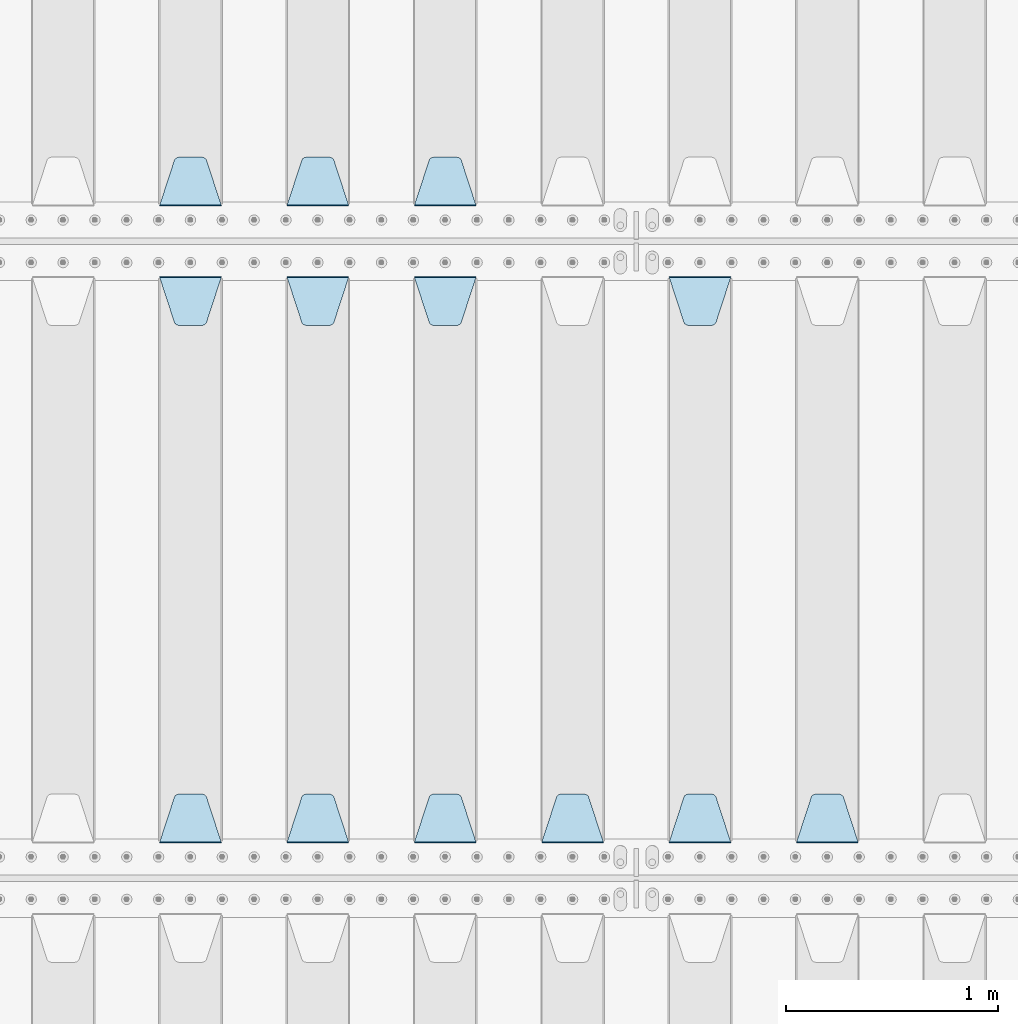
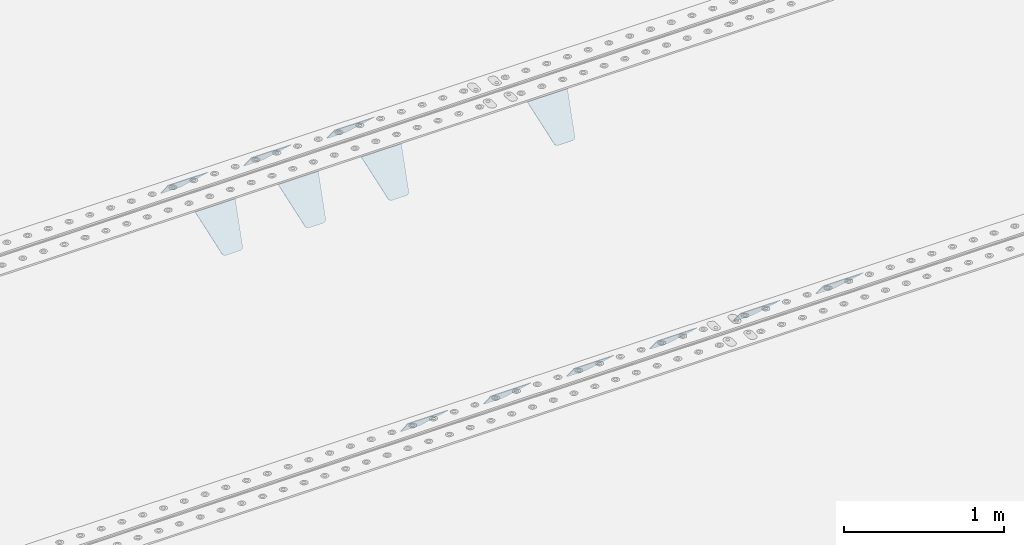
# One storey, part 207 of 257: 13 plates.
"""IFC2X3 building model written with IfcOpenShell, lengths in millimetres."""

from ifc_helpers import new_model, si_unit, frame, origin_with_axes, place, context, subcontext, project, spatial, faceted_brep, material, type_object, element, save


model = new_model("IFC2X3")

# Units and contexts
model_context = context("Model", 3, precision=1e-05, world=origin_with_axes())
body_context = subcontext(model_context, "Body", "Model", "MODEL_VIEW")
ifc_project = project(units=[si_unit("LENGTHUNIT", "METRE", prefix="MILLI"), si_unit("AREAUNIT", "SQUARE_METRE"), si_unit("VOLUMEUNIT", "CUBIC_METRE"), si_unit("MASSUNIT", "GRAM", prefix="KILO"), si_unit("TIMEUNIT", "SECOND"), si_unit("PLANEANGLEUNIT", "RADIAN"), si_unit("SOLIDANGLEUNIT", "STERADIAN"), si_unit("THERMODYNAMICTEMPERATUREUNIT", "DEGREE_CELSIUS"), si_unit("LUMINOUSINTENSITYUNIT", "LUMEN")], contexts=[model_context])

# Site, building, storey
site_placement = place(None, origin_with_axes())
site = spatial("IfcSite", under=ifc_project, at=site_placement, CompositionType="ELEMENT")
building_placement = place(site_placement, origin_with_axes())
building = spatial("IfcBuilding", under=site, at=building_placement, Name="Standard", CompositionType="ELEMENT")
storey_placement = place(building_placement, origin_with_axes())
storey = spatial("IfcBuildingStorey", under=building, at=storey_placement, Name="Undefined", CompositionType="ELEMENT", Elevation=0.0)

# Plates
ifc_material = material(Name="STEEL/S355N")
plate_type = type_object("IfcPlateType", PredefinedType="NOTDEFINED")
plate_1_placement = place(storey_placement, frame((47195.0, 6168.23223304703, -1.76776695296758), z_axis=(0.0, 0.707106781186547, -0.707106781186548), x_axis=(-1.0, 0.0, 0.0)))
element("IfcPlate", 1, at=plate_1_placement, inside=storey, type_object=plate_type, material=ifc_material, context=body_context, shape_type="Brep", body=[
    faceted_brep([(0.0, -2.5, 0.0), (69.345504679477, -2.50000000000091, 300.17173142483), (69.345504679477, 2.5, 300.171731424831), (0.0, 2.5, 0.0), (70.927406119954, -2.50000000000091, 304.8974424154), (70.927406119954, 2.5, 304.8974424154), (73.3818627772271, -2.50000000000091, 309.234538108527), (73.3818627772271, 2.49999999999909, 309.234538108527), (76.6187032999587, -2.5, 313.023683126103), (76.6187032999587, 2.5, 313.023683126103), (80.5190132705029, -2.5, 316.125672595372), (80.5190132705029, 2.5, 316.125672595371), (84.9395038596849, -2.5, 318.426546230476), (84.9395038596849, 2.5, 318.426546230477), (89.7177759439219, -2.5, 319.841774983275), (89.7177759439219, 2.5, 319.841774983275), (94.6782862926484, -2.5, 320.319366455079), (94.6782862926484, 2.5, 320.319366455079), (195.321713707352, -2.5, 320.319366455079), (195.321713707352, 2.5, 320.319366455079), (200.282224056078, -2.5, 319.841774983275), (200.282224056078, 2.49999999999909, 319.841774983275), (205.060496140315, -2.5, 318.426546230476), (205.060496140315, 2.49999999999909, 318.426546230475), (209.480986729497, -2.5, 316.125672595371), (209.480986729497, 2.5, 316.125672595371), (213.381296700041, -2.50000000000091, 313.023683126102), (213.381296700041, 2.5, 313.023683126103), (216.618137222766, -2.50000000000091, 309.234538108527), (216.618137222766, 2.5, 309.234538108527), (219.072593880039, -2.5, 304.897442415399), (219.072593880039, 2.5, 304.897442415399), (220.654495320523, -2.50000000000091, 300.17173142483), (220.654495320523, 2.5, 300.171731424831), (290.0, -2.50000000000091, 0.0), (290.0, 2.5, 9.09494701772928e-13)], [[[0, 1, 2, 3]], [[1, 4, 5, 2]], [[4, 6, 7, 5]], [[6, 8, 9, 7]], [[8, 10, 11, 9]], [[10, 12, 13, 11]], [[12, 14, 15, 13]], [[14, 16, 17, 15]], [[16, 18, 19, 17]], [[18, 20, 21, 19]], [[20, 22, 23, 21]], [[22, 24, 25, 23]], [[24, 26, 27, 25]], [[26, 28, 29, 27]], [[28, 30, 31, 29]], [[30, 32, 33, 31]], [[32, 34, 35, 33]], [[34, 0, 3, 35]], [[5, 7, 9, 11, 13, 15, 17, 19, 21, 23, 25, 27, 29, 31, 33, 35, 3, 2]], [[34, 32, 30, 28, 26, 24, 22, 20, 18, 16, 14, 12, 10, 8, 6, 4, 1, 0]]]),
])
plate_2_placement = place(storey_placement, frame((46595.0, 6168.23223304703, -1.76776695296758), z_axis=(0.0, 0.707106781186547, -0.707106781186548), x_axis=(-1.0, 0.0, 0.0)))
element("IfcPlate", 2, at=plate_2_placement, inside=storey, type_object=plate_type, material=ifc_material, context=body_context, shape_type="Brep", body=[
    faceted_brep([(0.0, -2.5, 0.0), (69.345504679477, -2.50000000000091, 300.17173142483), (69.345504679477, 2.5, 300.171731424831), (0.0, 2.5, 0.0), (70.927406119954, -2.50000000000091, 304.8974424154), (70.927406119954, 2.5, 304.8974424154), (73.3818627772271, -2.50000000000091, 309.234538108527), (73.3818627772271, 2.49999999999909, 309.234538108527), (76.6187032999587, -2.5, 313.023683126103), (76.6187032999587, 2.5, 313.023683126103), (80.5190132705029, -2.5, 316.125672595372), (80.5190132705029, 2.5, 316.125672595371), (84.9395038596849, -2.5, 318.426546230476), (84.9395038596849, 2.5, 318.426546230477), (89.7177759439219, -2.5, 319.841774983275), (89.7177759439219, 2.5, 319.841774983275), (94.6782862926484, -2.5, 320.319366455079), (94.6782862926484, 2.5, 320.319366455079), (195.321713707352, -2.5, 320.319366455079), (195.321713707352, 2.5, 320.319366455079), (200.282224056078, -2.5, 319.841774983275), (200.282224056078, 2.49999999999909, 319.841774983275), (205.060496140315, -2.5, 318.426546230476), (205.060496140315, 2.49999999999909, 318.426546230475), (209.480986729497, -2.5, 316.125672595371), (209.480986729497, 2.5, 316.125672595371), (213.381296700041, -2.50000000000091, 313.023683126102), (213.381296700041, 2.5, 313.023683126103), (216.618137222766, -2.50000000000091, 309.234538108527), (216.618137222766, 2.5, 309.234538108527), (219.072593880039, -2.5, 304.897442415399), (219.072593880039, 2.5, 304.897442415399), (220.654495320523, -2.50000000000091, 300.17173142483), (220.654495320523, 2.5, 300.171731424831), (290.0, -2.50000000000091, 0.0), (290.0, 2.5, 9.09494701772928e-13)], [[[0, 1, 2, 3]], [[1, 4, 5, 2]], [[4, 6, 7, 5]], [[6, 8, 9, 7]], [[8, 10, 11, 9]], [[10, 12, 13, 11]], [[12, 14, 15, 13]], [[14, 16, 17, 15]], [[16, 18, 19, 17]], [[18, 20, 21, 19]], [[20, 22, 23, 21]], [[22, 24, 25, 23]], [[24, 26, 27, 25]], [[26, 28, 29, 27]], [[28, 30, 31, 29]], [[30, 32, 33, 31]], [[32, 34, 35, 33]], [[34, 0, 3, 35]], [[5, 7, 9, 11, 13, 15, 17, 19, 21, 23, 25, 27, 29, 31, 33, 35, 3, 2]], [[34, 32, 30, 28, 26, 24, 22, 20, 18, 16, 14, 12, 10, 8, 6, 4, 1, 0]]]),
])
plate_3_placement = place(storey_placement, frame((45995.0, 6168.23223304703, -1.76776695296758), z_axis=(0.0, 0.707106781186547, -0.707106781186548), x_axis=(-1.0, 0.0, 0.0)))
element("IfcPlate", 3, at=plate_3_placement, inside=storey, type_object=plate_type, material=ifc_material, context=body_context, shape_type="Brep", body=[
    faceted_brep([(0.0, -2.5, 0.0), (69.345504679477, -2.50000000000091, 300.17173142483), (69.345504679477, 2.5, 300.171731424831), (0.0, 2.5, 0.0), (70.927406119954, -2.50000000000091, 304.8974424154), (70.927406119954, 2.5, 304.8974424154), (73.3818627772271, -2.50000000000091, 309.234538108527), (73.3818627772271, 2.49999999999909, 309.234538108527), (76.6187032999587, -2.5, 313.023683126103), (76.6187032999587, 2.5, 313.023683126103), (80.5190132705029, -2.5, 316.125672595372), (80.5190132705029, 2.5, 316.125672595371), (84.9395038596849, -2.5, 318.426546230476), (84.9395038596849, 2.5, 318.426546230477), (89.7177759439219, -2.5, 319.841774983275), (89.7177759439219, 2.5, 319.841774983275), (94.6782862926484, -2.5, 320.319366455079), (94.6782862926484, 2.5, 320.319366455079), (195.321713707352, -2.5, 320.319366455079), (195.321713707352, 2.5, 320.319366455079), (200.282224056078, -2.5, 319.841774983275), (200.282224056078, 2.49999999999909, 319.841774983275), (205.060496140315, -2.5, 318.426546230476), (205.060496140315, 2.49999999999909, 318.426546230475), (209.480986729497, -2.5, 316.125672595371), (209.480986729497, 2.5, 316.125672595371), (213.381296700041, -2.50000000000091, 313.023683126102), (213.381296700041, 2.5, 313.023683126103), (216.618137222766, -2.50000000000091, 309.234538108527), (216.618137222766, 2.5, 309.234538108527), (219.072593880039, -2.5, 304.897442415399), (219.072593880039, 2.5, 304.897442415399), (220.654495320523, -2.50000000000091, 300.17173142483), (220.654495320523, 2.5, 300.171731424831), (290.0, -2.50000000000091, 0.0), (290.0, 2.5, 9.09494701772928e-13)], [[[0, 1, 2, 3]], [[1, 4, 5, 2]], [[4, 6, 7, 5]], [[6, 8, 9, 7]], [[8, 10, 11, 9]], [[10, 12, 13, 11]], [[12, 14, 15, 13]], [[14, 16, 17, 15]], [[16, 18, 19, 17]], [[18, 20, 21, 19]], [[20, 22, 23, 21]], [[22, 24, 25, 23]], [[24, 26, 27, 25]], [[26, 28, 29, 27]], [[28, 30, 31, 29]], [[30, 32, 33, 31]], [[32, 34, 35, 33]], [[34, 0, 3, 35]], [[5, 7, 9, 11, 13, 15, 17, 19, 21, 23, 25, 27, 29, 31, 33, 35, 3, 2]], [[34, 32, 30, 28, 26, 24, 22, 20, 18, 16, 14, 12, 10, 8, 6, 4, 1, 0]]]),
])
plate_4_placement = place(storey_placement, frame((48995.0, 3168.23223304703, -1.76776695296758), z_axis=(0.0, 0.707106781186547, -0.707106781186548), x_axis=(-1.0, 0.0, 0.0)))
element("IfcPlate", 4, at=plate_4_placement, inside=storey, type_object=plate_type, material=ifc_material, context=body_context, shape_type="Brep", body=[
    faceted_brep([(0.0, -2.5, 0.0), (69.345504679477, -2.50000000000091, 300.17173142483), (69.345504679477, 2.5, 300.171731424831), (0.0, 2.5, 0.0), (70.927406119954, -2.50000000000091, 304.8974424154), (70.927406119954, 2.5, 304.8974424154), (73.3818627772271, -2.50000000000091, 309.234538108527), (73.3818627772271, 2.49999999999909, 309.234538108527), (76.6187032999587, -2.5, 313.023683126103), (76.6187032999587, 2.5, 313.023683126103), (80.5190132705029, -2.5, 316.125672595372), (80.5190132705029, 2.5, 316.125672595371), (84.9395038596849, -2.5, 318.426546230476), (84.9395038596849, 2.5, 318.426546230477), (89.7177759439219, -2.5, 319.841774983275), (89.7177759439219, 2.5, 319.841774983275), (94.6782862926484, -2.5, 320.319366455079), (94.6782862926484, 2.5, 320.319366455079), (195.321713707352, -2.5, 320.319366455079), (195.321713707352, 2.5, 320.319366455079), (200.282224056078, -2.5, 319.841774983275), (200.282224056078, 2.49999999999909, 319.841774983275), (205.060496140315, -2.5, 318.426546230476), (205.060496140315, 2.49999999999909, 318.426546230475), (209.480986729497, -2.5, 316.125672595371), (209.480986729497, 2.5, 316.125672595371), (213.381296700041, -2.50000000000091, 313.023683126102), (213.381296700041, 2.5, 313.023683126103), (216.618137222766, -2.50000000000091, 309.234538108527), (216.618137222766, 2.5, 309.234538108527), (219.072593880039, -2.5, 304.897442415399), (219.072593880039, 2.5, 304.897442415399), (220.654495320523, -2.50000000000091, 300.17173142483), (220.654495320523, 2.5, 300.171731424831), (290.0, -2.50000000000091, 0.0), (290.0, 2.5, 9.09494701772928e-13)], [[[0, 1, 2, 3]], [[1, 4, 5, 2]], [[4, 6, 7, 5]], [[6, 8, 9, 7]], [[8, 10, 11, 9]], [[10, 12, 13, 11]], [[12, 14, 15, 13]], [[14, 16, 17, 15]], [[16, 18, 19, 17]], [[18, 20, 21, 19]], [[20, 22, 23, 21]], [[22, 24, 25, 23]], [[24, 26, 27, 25]], [[26, 28, 29, 27]], [[28, 30, 31, 29]], [[30, 32, 33, 31]], [[32, 34, 35, 33]], [[34, 0, 3, 35]], [[5, 7, 9, 11, 13, 15, 17, 19, 21, 23, 25, 27, 29, 31, 33, 35, 3, 2]], [[34, 32, 30, 28, 26, 24, 22, 20, 18, 16, 14, 12, 10, 8, 6, 4, 1, 0]]]),
])
plate_5_placement = place(storey_placement, frame((48105.0, 5831.76776695594, -1.767766952965), z_axis=(0.0, -0.707106781186548, -0.707106781186547), x_axis=(1.0, 0.0, 0.0)))
element("IfcPlate", 5, at=plate_5_placement, inside=storey, type_object=plate_type, material=ifc_material, context=body_context, shape_type="Brep", body=[
    faceted_brep([(0.0, -2.5, 0.0), (69.345504679477, -2.50000000000091, 300.17173142483), (69.345504679477, 2.5, 300.171731424831), (0.0, 2.5, 0.0), (70.927406119954, -2.50000000000091, 304.8974424154), (70.927406119954, 2.5, 304.8974424154), (73.3818627772271, -2.50000000000091, 309.234538108527), (73.3818627772271, 2.49999999999909, 309.234538108527), (76.6187032999587, -2.5, 313.023683126103), (76.6187032999587, 2.5, 313.023683126103), (80.5190132705029, -2.5, 316.125672595372), (80.5190132705029, 2.5, 316.125672595371), (84.9395038596849, -2.5, 318.426546230476), (84.9395038596849, 2.5, 318.426546230477), (89.7177759439219, -2.5, 319.841774983275), (89.7177759439219, 2.5, 319.841774983275), (94.6782862926484, -2.5, 320.319366455079), (94.6782862926484, 2.5, 320.319366455079), (195.321713707352, -2.5, 320.319366455079), (195.321713707352, 2.5, 320.319366455079), (200.282224056078, -2.5, 319.841774983275), (200.282224056078, 2.49999999999909, 319.841774983275), (205.060496140315, -2.5, 318.426546230476), (205.060496140315, 2.49999999999909, 318.426546230475), (209.480986729497, -2.5, 316.125672595371), (209.480986729497, 2.5, 316.125672595371), (213.381296700041, -2.50000000000091, 313.023683126102), (213.381296700041, 2.5, 313.023683126103), (216.618137222766, -2.50000000000091, 309.234538108527), (216.618137222766, 2.5, 309.234538108527), (219.072593880039, -2.5, 304.897442415399), (219.072593880039, 2.5, 304.897442415399), (220.654495320523, -2.50000000000091, 300.17173142483), (220.654495320523, 2.5, 300.171731424831), (290.0, -2.50000000000091, 0.0), (290.0, 2.5, 9.09494701772928e-13)], [[[0, 1, 2, 3]], [[1, 4, 5, 2]], [[4, 6, 7, 5]], [[6, 8, 9, 7]], [[8, 10, 11, 9]], [[10, 12, 13, 11]], [[12, 14, 15, 13]], [[14, 16, 17, 15]], [[16, 18, 19, 17]], [[18, 20, 21, 19]], [[20, 22, 23, 21]], [[22, 24, 25, 23]], [[24, 26, 27, 25]], [[26, 28, 29, 27]], [[28, 30, 31, 29]], [[30, 32, 33, 31]], [[32, 34, 35, 33]], [[34, 0, 3, 35]], [[5, 7, 9, 11, 13, 15, 17, 19, 21, 23, 25, 27, 29, 31, 33, 35, 3, 2]], [[34, 32, 30, 28, 26, 24, 22, 20, 18, 16, 14, 12, 10, 8, 6, 4, 1, 0]]]),
])
plate_6_placement = place(storey_placement, frame((48395.0, 3168.23223304703, -1.76776695296758), z_axis=(0.0, 0.707106781186547, -0.707106781186548), x_axis=(-1.0, 0.0, 0.0)))
element("IfcPlate", 6, at=plate_6_placement, inside=storey, type_object=plate_type, material=ifc_material, context=body_context, shape_type="Brep", body=[
    faceted_brep([(0.0, -2.5, 0.0), (69.345504679477, -2.50000000000091, 300.17173142483), (69.345504679477, 2.5, 300.171731424831), (0.0, 2.5, 0.0), (70.927406119954, -2.50000000000091, 304.8974424154), (70.927406119954, 2.5, 304.8974424154), (73.3818627772271, -2.50000000000091, 309.234538108527), (73.3818627772271, 2.49999999999909, 309.234538108527), (76.6187032999587, -2.5, 313.023683126103), (76.6187032999587, 2.5, 313.023683126103), (80.5190132705029, -2.5, 316.125672595372), (80.5190132705029, 2.5, 316.125672595371), (84.9395038596849, -2.5, 318.426546230476), (84.9395038596849, 2.5, 318.426546230477), (89.7177759439219, -2.5, 319.841774983275), (89.7177759439219, 2.5, 319.841774983275), (94.6782862926484, -2.5, 320.319366455079), (94.6782862926484, 2.5, 320.319366455079), (195.321713707352, -2.5, 320.319366455079), (195.321713707352, 2.5, 320.319366455079), (200.282224056078, -2.5, 319.841774983275), (200.282224056078, 2.49999999999909, 319.841774983275), (205.060496140315, -2.5, 318.426546230476), (205.060496140315, 2.49999999999909, 318.426546230475), (209.480986729497, -2.5, 316.125672595371), (209.480986729497, 2.5, 316.125672595371), (213.381296700041, -2.50000000000091, 313.023683126102), (213.381296700041, 2.5, 313.023683126103), (216.618137222766, -2.50000000000091, 309.234538108527), (216.618137222766, 2.5, 309.234538108527), (219.072593880039, -2.5, 304.897442415399), (219.072593880039, 2.5, 304.897442415399), (220.654495320523, -2.50000000000091, 300.17173142483), (220.654495320523, 2.5, 300.171731424831), (290.0, -2.50000000000091, 0.0), (290.0, 2.5, 9.09494701772928e-13)], [[[0, 1, 2, 3]], [[1, 4, 5, 2]], [[4, 6, 7, 5]], [[6, 8, 9, 7]], [[8, 10, 11, 9]], [[10, 12, 13, 11]], [[12, 14, 15, 13]], [[14, 16, 17, 15]], [[16, 18, 19, 17]], [[18, 20, 21, 19]], [[20, 22, 23, 21]], [[22, 24, 25, 23]], [[24, 26, 27, 25]], [[26, 28, 29, 27]], [[28, 30, 31, 29]], [[30, 32, 33, 31]], [[32, 34, 35, 33]], [[34, 0, 3, 35]], [[5, 7, 9, 11, 13, 15, 17, 19, 21, 23, 25, 27, 29, 31, 33, 35, 3, 2]], [[34, 32, 30, 28, 26, 24, 22, 20, 18, 16, 14, 12, 10, 8, 6, 4, 1, 0]]]),
])
plate_7_placement = place(storey_placement, frame((47795.0, 3168.23223304703, -1.76776695296758), z_axis=(0.0, 0.707106781186547, -0.707106781186548), x_axis=(-1.0, 0.0, 0.0)))
element("IfcPlate", 7, at=plate_7_placement, inside=storey, type_object=plate_type, material=ifc_material, context=body_context, shape_type="Brep", body=[
    faceted_brep([(0.0, -2.5, 0.0), (69.345504679477, -2.50000000000091, 300.17173142483), (69.345504679477, 2.5, 300.171731424831), (0.0, 2.5, 0.0), (70.927406119954, -2.50000000000091, 304.8974424154), (70.927406119954, 2.5, 304.8974424154), (73.3818627772271, -2.50000000000091, 309.234538108527), (73.3818627772271, 2.49999999999909, 309.234538108527), (76.6187032999587, -2.5, 313.023683126103), (76.6187032999587, 2.5, 313.023683126103), (80.5190132705029, -2.5, 316.125672595372), (80.5190132705029, 2.5, 316.125672595371), (84.9395038596849, -2.5, 318.426546230476), (84.9395038596849, 2.5, 318.426546230477), (89.7177759439219, -2.5, 319.841774983275), (89.7177759439219, 2.5, 319.841774983275), (94.6782862926484, -2.5, 320.319366455079), (94.6782862926484, 2.5, 320.319366455079), (195.321713707352, -2.5, 320.319366455079), (195.321713707352, 2.5, 320.319366455079), (200.282224056078, -2.5, 319.841774983275), (200.282224056078, 2.49999999999909, 319.841774983275), (205.060496140315, -2.5, 318.426546230476), (205.060496140315, 2.49999999999909, 318.426546230475), (209.480986729497, -2.5, 316.125672595371), (209.480986729497, 2.5, 316.125672595371), (213.381296700041, -2.50000000000091, 313.023683126102), (213.381296700041, 2.5, 313.023683126103), (216.618137222766, -2.50000000000091, 309.234538108527), (216.618137222766, 2.5, 309.234538108527), (219.072593880039, -2.5, 304.897442415399), (219.072593880039, 2.5, 304.897442415399), (220.654495320523, -2.50000000000091, 300.17173142483), (220.654495320523, 2.5, 300.171731424831), (290.0, -2.50000000000091, 0.0), (290.0, 2.5, 9.09494701772928e-13)], [[[0, 1, 2, 3]], [[1, 4, 5, 2]], [[4, 6, 7, 5]], [[6, 8, 9, 7]], [[8, 10, 11, 9]], [[10, 12, 13, 11]], [[12, 14, 15, 13]], [[14, 16, 17, 15]], [[16, 18, 19, 17]], [[18, 20, 21, 19]], [[20, 22, 23, 21]], [[22, 24, 25, 23]], [[24, 26, 27, 25]], [[26, 28, 29, 27]], [[28, 30, 31, 29]], [[30, 32, 33, 31]], [[32, 34, 35, 33]], [[34, 0, 3, 35]], [[5, 7, 9, 11, 13, 15, 17, 19, 21, 23, 25, 27, 29, 31, 33, 35, 3, 2]], [[34, 32, 30, 28, 26, 24, 22, 20, 18, 16, 14, 12, 10, 8, 6, 4, 1, 0]]]),
])
plate_8_placement = place(storey_placement, frame((46905.0, 5831.76776695594, -1.767766952965), z_axis=(0.0, -0.707106781186548, -0.707106781186547), x_axis=(1.0, 0.0, 0.0)))
element("IfcPlate", 8, at=plate_8_placement, inside=storey, type_object=plate_type, material=ifc_material, context=body_context, shape_type="Brep", body=[
    faceted_brep([(0.0, -2.5, 0.0), (69.345504679477, -2.50000000000091, 300.17173142483), (69.345504679477, 2.5, 300.171731424831), (0.0, 2.5, 0.0), (70.927406119954, -2.50000000000091, 304.8974424154), (70.927406119954, 2.5, 304.8974424154), (73.3818627772271, -2.50000000000091, 309.234538108527), (73.3818627772271, 2.49999999999909, 309.234538108527), (76.6187032999587, -2.5, 313.023683126103), (76.6187032999587, 2.5, 313.023683126103), (80.5190132705029, -2.5, 316.125672595372), (80.5190132705029, 2.5, 316.125672595371), (84.9395038596849, -2.5, 318.426546230476), (84.9395038596849, 2.5, 318.426546230477), (89.7177759439219, -2.5, 319.841774983275), (89.7177759439219, 2.5, 319.841774983275), (94.6782862926484, -2.5, 320.319366455079), (94.6782862926484, 2.5, 320.319366455079), (195.321713707352, -2.5, 320.319366455079), (195.321713707352, 2.5, 320.319366455079), (200.282224056078, -2.5, 319.841774983275), (200.282224056078, 2.49999999999909, 319.841774983275), (205.060496140315, -2.5, 318.426546230476), (205.060496140315, 2.49999999999909, 318.426546230475), (209.480986729497, -2.5, 316.125672595371), (209.480986729497, 2.5, 316.125672595371), (213.381296700041, -2.50000000000091, 313.023683126102), (213.381296700041, 2.5, 313.023683126103), (216.618137222766, -2.50000000000091, 309.234538108527), (216.618137222766, 2.5, 309.234538108527), (219.072593880039, -2.5, 304.897442415399), (219.072593880039, 2.5, 304.897442415399), (220.654495320523, -2.50000000000091, 300.17173142483), (220.654495320523, 2.5, 300.171731424831), (290.0, -2.50000000000091, 0.0), (290.0, 2.5, 9.09494701772928e-13)], [[[0, 1, 2, 3]], [[1, 4, 5, 2]], [[4, 6, 7, 5]], [[6, 8, 9, 7]], [[8, 10, 11, 9]], [[10, 12, 13, 11]], [[12, 14, 15, 13]], [[14, 16, 17, 15]], [[16, 18, 19, 17]], [[18, 20, 21, 19]], [[20, 22, 23, 21]], [[22, 24, 25, 23]], [[24, 26, 27, 25]], [[26, 28, 29, 27]], [[28, 30, 31, 29]], [[30, 32, 33, 31]], [[32, 34, 35, 33]], [[34, 0, 3, 35]], [[5, 7, 9, 11, 13, 15, 17, 19, 21, 23, 25, 27, 29, 31, 33, 35, 3, 2]], [[34, 32, 30, 28, 26, 24, 22, 20, 18, 16, 14, 12, 10, 8, 6, 4, 1, 0]]]),
])
plate_9_placement = place(storey_placement, frame((47195.0, 3168.23223304703, -1.76776695296758), z_axis=(0.0, 0.707106781186547, -0.707106781186548), x_axis=(-1.0, 0.0, 0.0)))
element("IfcPlate", 9, at=plate_9_placement, inside=storey, type_object=plate_type, material=ifc_material, context=body_context, shape_type="Brep", body=[
    faceted_brep([(0.0, -2.5, 0.0), (69.345504679477, -2.50000000000091, 300.17173142483), (69.345504679477, 2.5, 300.171731424831), (0.0, 2.5, 0.0), (70.927406119954, -2.50000000000091, 304.8974424154), (70.927406119954, 2.5, 304.8974424154), (73.3818627772271, -2.50000000000091, 309.234538108527), (73.3818627772271, 2.49999999999909, 309.234538108527), (76.6187032999587, -2.5, 313.023683126103), (76.6187032999587, 2.5, 313.023683126103), (80.5190132705029, -2.5, 316.125672595372), (80.5190132705029, 2.5, 316.125672595371), (84.9395038596849, -2.5, 318.426546230476), (84.9395038596849, 2.5, 318.426546230477), (89.7177759439219, -2.5, 319.841774983275), (89.7177759439219, 2.5, 319.841774983275), (94.6782862926484, -2.5, 320.319366455079), (94.6782862926484, 2.5, 320.319366455079), (195.321713707352, -2.5, 320.319366455079), (195.321713707352, 2.5, 320.319366455079), (200.282224056078, -2.5, 319.841774983275), (200.282224056078, 2.49999999999909, 319.841774983275), (205.060496140315, -2.5, 318.426546230476), (205.060496140315, 2.49999999999909, 318.426546230475), (209.480986729497, -2.5, 316.125672595371), (209.480986729497, 2.5, 316.125672595371), (213.381296700041, -2.50000000000091, 313.023683126102), (213.381296700041, 2.5, 313.023683126103), (216.618137222766, -2.50000000000091, 309.234538108527), (216.618137222766, 2.5, 309.234538108527), (219.072593880039, -2.5, 304.897442415399), (219.072593880039, 2.5, 304.897442415399), (220.654495320523, -2.50000000000091, 300.17173142483), (220.654495320523, 2.5, 300.171731424831), (290.0, -2.50000000000091, 0.0), (290.0, 2.5, 9.09494701772928e-13)], [[[0, 1, 2, 3]], [[1, 4, 5, 2]], [[4, 6, 7, 5]], [[6, 8, 9, 7]], [[8, 10, 11, 9]], [[10, 12, 13, 11]], [[12, 14, 15, 13]], [[14, 16, 17, 15]], [[16, 18, 19, 17]], [[18, 20, 21, 19]], [[20, 22, 23, 21]], [[22, 24, 25, 23]], [[24, 26, 27, 25]], [[26, 28, 29, 27]], [[28, 30, 31, 29]], [[30, 32, 33, 31]], [[32, 34, 35, 33]], [[34, 0, 3, 35]], [[5, 7, 9, 11, 13, 15, 17, 19, 21, 23, 25, 27, 29, 31, 33, 35, 3, 2]], [[34, 32, 30, 28, 26, 24, 22, 20, 18, 16, 14, 12, 10, 8, 6, 4, 1, 0]]]),
])
plate_10_placement = place(storey_placement, frame((46305.0, 5831.76776695594, -1.767766952965), z_axis=(0.0, -0.707106781186548, -0.707106781186547), x_axis=(1.0, 0.0, 0.0)))
element("IfcPlate", 10, at=plate_10_placement, inside=storey, type_object=plate_type, material=ifc_material, context=body_context, shape_type="Brep", body=[
    faceted_brep([(0.0, -2.5, 0.0), (69.345504679477, -2.50000000000091, 300.17173142483), (69.345504679477, 2.5, 300.171731424831), (0.0, 2.5, 0.0), (70.927406119954, -2.50000000000091, 304.8974424154), (70.927406119954, 2.5, 304.8974424154), (73.3818627772271, -2.50000000000091, 309.234538108527), (73.3818627772271, 2.49999999999909, 309.234538108527), (76.6187032999587, -2.5, 313.023683126103), (76.6187032999587, 2.5, 313.023683126103), (80.5190132705029, -2.5, 316.125672595372), (80.5190132705029, 2.5, 316.125672595371), (84.9395038596849, -2.5, 318.426546230476), (84.9395038596849, 2.5, 318.426546230477), (89.7177759439219, -2.5, 319.841774983275), (89.7177759439219, 2.5, 319.841774983275), (94.6782862926484, -2.5, 320.319366455079), (94.6782862926484, 2.5, 320.319366455079), (195.321713707352, -2.5, 320.319366455079), (195.321713707352, 2.5, 320.319366455079), (200.282224056078, -2.5, 319.841774983275), (200.282224056078, 2.49999999999909, 319.841774983275), (205.060496140315, -2.5, 318.426546230476), (205.060496140315, 2.49999999999909, 318.426546230475), (209.480986729497, -2.5, 316.125672595371), (209.480986729497, 2.5, 316.125672595371), (213.381296700041, -2.50000000000091, 313.023683126102), (213.381296700041, 2.5, 313.023683126103), (216.618137222766, -2.50000000000091, 309.234538108527), (216.618137222766, 2.5, 309.234538108527), (219.072593880039, -2.5, 304.897442415399), (219.072593880039, 2.5, 304.897442415399), (220.654495320523, -2.50000000000091, 300.17173142483), (220.654495320523, 2.5, 300.171731424831), (290.0, -2.50000000000091, 0.0), (290.0, 2.5, 9.09494701772928e-13)], [[[0, 1, 2, 3]], [[1, 4, 5, 2]], [[4, 6, 7, 5]], [[6, 8, 9, 7]], [[8, 10, 11, 9]], [[10, 12, 13, 11]], [[12, 14, 15, 13]], [[14, 16, 17, 15]], [[16, 18, 19, 17]], [[18, 20, 21, 19]], [[20, 22, 23, 21]], [[22, 24, 25, 23]], [[24, 26, 27, 25]], [[26, 28, 29, 27]], [[28, 30, 31, 29]], [[30, 32, 33, 31]], [[32, 34, 35, 33]], [[34, 0, 3, 35]], [[5, 7, 9, 11, 13, 15, 17, 19, 21, 23, 25, 27, 29, 31, 33, 35, 3, 2]], [[34, 32, 30, 28, 26, 24, 22, 20, 18, 16, 14, 12, 10, 8, 6, 4, 1, 0]]]),
])
plate_11_placement = place(storey_placement, frame((46595.0, 3168.23223304703, -1.76776695296758), z_axis=(0.0, 0.707106781186547, -0.707106781186548), x_axis=(-1.0, 0.0, 0.0)))
element("IfcPlate", 11, at=plate_11_placement, inside=storey, type_object=plate_type, material=ifc_material, context=body_context, shape_type="Brep", body=[
    faceted_brep([(0.0, -2.5, 0.0), (69.345504679477, -2.50000000000091, 300.17173142483), (69.345504679477, 2.5, 300.171731424831), (0.0, 2.5, 0.0), (70.927406119954, -2.50000000000091, 304.8974424154), (70.927406119954, 2.5, 304.8974424154), (73.3818627772271, -2.50000000000091, 309.234538108527), (73.3818627772271, 2.49999999999909, 309.234538108527), (76.6187032999587, -2.5, 313.023683126103), (76.6187032999587, 2.5, 313.023683126103), (80.5190132705029, -2.5, 316.125672595372), (80.5190132705029, 2.5, 316.125672595371), (84.9395038596849, -2.5, 318.426546230476), (84.9395038596849, 2.5, 318.426546230477), (89.7177759439219, -2.5, 319.841774983275), (89.7177759439219, 2.5, 319.841774983275), (94.6782862926484, -2.5, 320.319366455079), (94.6782862926484, 2.5, 320.319366455079), (195.321713707352, -2.5, 320.319366455079), (195.321713707352, 2.5, 320.319366455079), (200.282224056078, -2.5, 319.841774983275), (200.282224056078, 2.49999999999909, 319.841774983275), (205.060496140315, -2.5, 318.426546230476), (205.060496140315, 2.49999999999909, 318.426546230475), (209.480986729497, -2.5, 316.125672595371), (209.480986729497, 2.5, 316.125672595371), (213.381296700041, -2.50000000000091, 313.023683126102), (213.381296700041, 2.5, 313.023683126103), (216.618137222766, -2.50000000000091, 309.234538108527), (216.618137222766, 2.5, 309.234538108527), (219.072593880039, -2.5, 304.897442415399), (219.072593880039, 2.5, 304.897442415399), (220.654495320523, -2.50000000000091, 300.17173142483), (220.654495320523, 2.5, 300.171731424831), (290.0, -2.50000000000091, 0.0), (290.0, 2.5, 9.09494701772928e-13)], [[[0, 1, 2, 3]], [[1, 4, 5, 2]], [[4, 6, 7, 5]], [[6, 8, 9, 7]], [[8, 10, 11, 9]], [[10, 12, 13, 11]], [[12, 14, 15, 13]], [[14, 16, 17, 15]], [[16, 18, 19, 17]], [[18, 20, 21, 19]], [[20, 22, 23, 21]], [[22, 24, 25, 23]], [[24, 26, 27, 25]], [[26, 28, 29, 27]], [[28, 30, 31, 29]], [[30, 32, 33, 31]], [[32, 34, 35, 33]], [[34, 0, 3, 35]], [[5, 7, 9, 11, 13, 15, 17, 19, 21, 23, 25, 27, 29, 31, 33, 35, 3, 2]], [[34, 32, 30, 28, 26, 24, 22, 20, 18, 16, 14, 12, 10, 8, 6, 4, 1, 0]]]),
])
plate_12_placement = place(storey_placement, frame((45705.0, 5831.76776695594, -1.767766952965), z_axis=(0.0, -0.707106781186548, -0.707106781186547), x_axis=(1.0, 0.0, 0.0)))
element("IfcPlate", 12, at=plate_12_placement, inside=storey, type_object=plate_type, material=ifc_material, context=body_context, shape_type="Brep", body=[
    faceted_brep([(0.0, -2.5, 0.0), (69.345504679477, -2.50000000000091, 300.17173142483), (69.345504679477, 2.5, 300.171731424831), (0.0, 2.5, 0.0), (70.927406119954, -2.50000000000091, 304.8974424154), (70.927406119954, 2.5, 304.8974424154), (73.3818627772271, -2.50000000000091, 309.234538108527), (73.3818627772271, 2.49999999999909, 309.234538108527), (76.6187032999587, -2.5, 313.023683126103), (76.6187032999587, 2.5, 313.023683126103), (80.5190132705029, -2.5, 316.125672595372), (80.5190132705029, 2.5, 316.125672595371), (84.9395038596849, -2.5, 318.426546230476), (84.9395038596849, 2.5, 318.426546230477), (89.7177759439219, -2.5, 319.841774983275), (89.7177759439219, 2.5, 319.841774983275), (94.6782862926484, -2.5, 320.319366455079), (94.6782862926484, 2.5, 320.319366455079), (195.321713707352, -2.5, 320.319366455079), (195.321713707352, 2.5, 320.319366455079), (200.282224056078, -2.5, 319.841774983275), (200.282224056078, 2.49999999999909, 319.841774983275), (205.060496140315, -2.5, 318.426546230476), (205.060496140315, 2.49999999999909, 318.426546230475), (209.480986729497, -2.5, 316.125672595371), (209.480986729497, 2.5, 316.125672595371), (213.381296700041, -2.50000000000091, 313.023683126102), (213.381296700041, 2.5, 313.023683126103), (216.618137222766, -2.50000000000091, 309.234538108527), (216.618137222766, 2.5, 309.234538108527), (219.072593880039, -2.5, 304.897442415399), (219.072593880039, 2.5, 304.897442415399), (220.654495320523, -2.50000000000091, 300.17173142483), (220.654495320523, 2.5, 300.171731424831), (290.0, -2.50000000000091, 0.0), (290.0, 2.5, 9.09494701772928e-13)], [[[0, 1, 2, 3]], [[1, 4, 5, 2]], [[4, 6, 7, 5]], [[6, 8, 9, 7]], [[8, 10, 11, 9]], [[10, 12, 13, 11]], [[12, 14, 15, 13]], [[14, 16, 17, 15]], [[16, 18, 19, 17]], [[18, 20, 21, 19]], [[20, 22, 23, 21]], [[22, 24, 25, 23]], [[24, 26, 27, 25]], [[26, 28, 29, 27]], [[28, 30, 31, 29]], [[30, 32, 33, 31]], [[32, 34, 35, 33]], [[34, 0, 3, 35]], [[5, 7, 9, 11, 13, 15, 17, 19, 21, 23, 25, 27, 29, 31, 33, 35, 3, 2]], [[34, 32, 30, 28, 26, 24, 22, 20, 18, 16, 14, 12, 10, 8, 6, 4, 1, 0]]]),
])
plate_13_placement = place(storey_placement, frame((45995.0, 3168.23223304703, -1.76776695296758), z_axis=(0.0, 0.707106781186547, -0.707106781186548), x_axis=(-1.0, 0.0, 0.0)))
element("IfcPlate", 13, at=plate_13_placement, inside=storey, type_object=plate_type, material=ifc_material, context=body_context, shape_type="Brep", body=[
    faceted_brep([(0.0, -2.5, 0.0), (69.345504679477, -2.50000000000091, 300.17173142483), (69.345504679477, 2.5, 300.171731424831), (0.0, 2.5, 0.0), (70.927406119954, -2.50000000000091, 304.8974424154), (70.927406119954, 2.5, 304.8974424154), (73.3818627772271, -2.50000000000091, 309.234538108527), (73.3818627772271, 2.49999999999909, 309.234538108527), (76.6187032999587, -2.5, 313.023683126103), (76.6187032999587, 2.5, 313.023683126103), (80.5190132705029, -2.5, 316.125672595372), (80.5190132705029, 2.5, 316.125672595371), (84.9395038596849, -2.5, 318.426546230476), (84.9395038596849, 2.5, 318.426546230477), (89.7177759439219, -2.5, 319.841774983275), (89.7177759439219, 2.5, 319.841774983275), (94.6782862926484, -2.5, 320.319366455079), (94.6782862926484, 2.5, 320.319366455079), (195.321713707352, -2.5, 320.319366455079), (195.321713707352, 2.5, 320.319366455079), (200.282224056078, -2.5, 319.841774983275), (200.282224056078, 2.49999999999909, 319.841774983275), (205.060496140315, -2.5, 318.426546230476), (205.060496140315, 2.49999999999909, 318.426546230475), (209.480986729497, -2.5, 316.125672595371), (209.480986729497, 2.5, 316.125672595371), (213.381296700041, -2.50000000000091, 313.023683126102), (213.381296700041, 2.5, 313.023683126103), (216.618137222766, -2.50000000000091, 309.234538108527), (216.618137222766, 2.5, 309.234538108527), (219.072593880039, -2.5, 304.897442415399), (219.072593880039, 2.5, 304.897442415399), (220.654495320523, -2.50000000000091, 300.17173142483), (220.654495320523, 2.5, 300.171731424831), (290.0, -2.50000000000091, 0.0), (290.0, 2.5, 9.09494701772928e-13)], [[[0, 1, 2, 3]], [[1, 4, 5, 2]], [[4, 6, 7, 5]], [[6, 8, 9, 7]], [[8, 10, 11, 9]], [[10, 12, 13, 11]], [[12, 14, 15, 13]], [[14, 16, 17, 15]], [[16, 18, 19, 17]], [[18, 20, 21, 19]], [[20, 22, 23, 21]], [[22, 24, 25, 23]], [[24, 26, 27, 25]], [[26, 28, 29, 27]], [[28, 30, 31, 29]], [[30, 32, 33, 31]], [[32, 34, 35, 33]], [[34, 0, 3, 35]], [[5, 7, 9, 11, 13, 15, 17, 19, 21, 23, 25, 27, 29, 31, 33, 35, 3, 2]], [[34, 32, 30, 28, 26, 24, 22, 20, 18, 16, 14, 12, 10, 8, 6, 4, 1, 0]]]),
])

save(model, "model.ifc")
